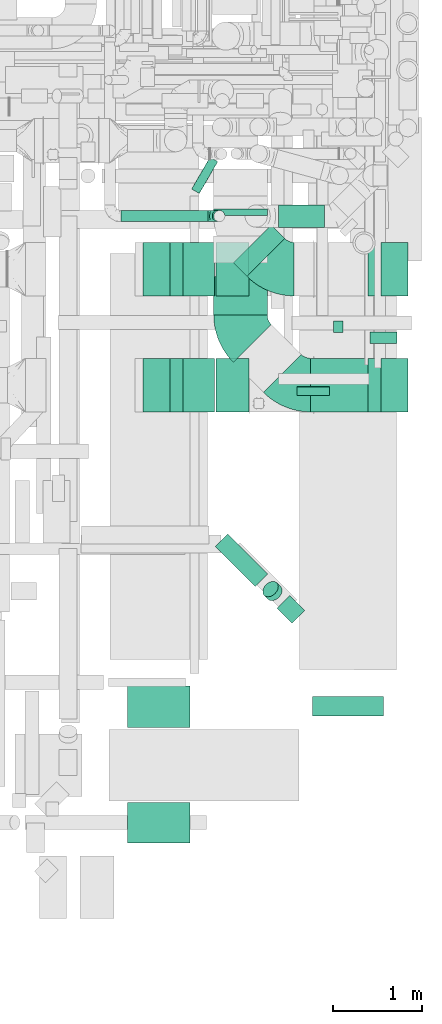
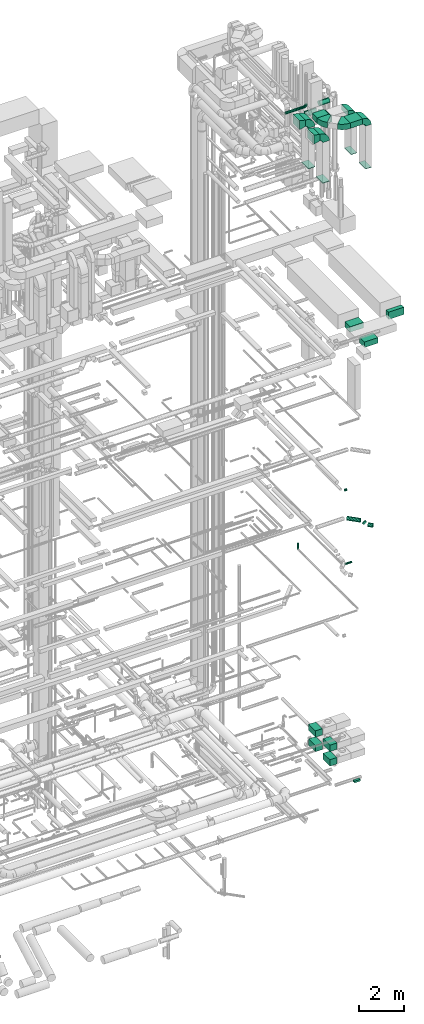
# One storey, part 297 of 337: 20 flow segments, 14 flow fittings.
"""IFC2X3 building model written with IfcOpenShell, lengths in millimetres."""

import ifcopenshell
import ifcopenshell.guid

model = None  # the IFC model being written
_history = None  # IfcOwnerHistory: only IFC2X3 demands one
_inside = {}  # id of a spatial element -> (the spatial element, [elements in it])
_under = {}  # id of a project, library or spatial element -> (it, [spatial elements below it])
_declared = {}  # id of a project -> (the project, [libraries it declares])
_typed = {}  # id of a type object -> (the type object, [elements of that type])
_made_of = {}  # id of a material, layer set ... -> (it, [elements and type objects made of it])


def new_model(schema):
    """Start an empty IFC model of exactly this schema.

    Asked for "IFC4X3", IfcOpenShell would pick the latest addendum, in which some entities
    have other attributes; the version numbers below select the first issue.
    IFC2X3 requires an IfcOwnerHistory on every rooted entity: one is made here for all.
    """
    global model, _history
    if schema == "IFC4X3":
        model = ifcopenshell.file(schema_version=(4, 3, 0, 0))
    else:
        model = ifcopenshell.file(schema=schema)
    _inside.clear()
    _under.clear()
    _declared.clear()
    _typed.clear()
    _made_of.clear()
    _history = None
    if model.schema == "IFC2X3":
        org = make("IfcOrganization", Name="unknown")
        user = make(
            "IfcPersonAndOrganization",
            ThePerson=make("IfcPerson", FamilyName="unknown"),
            TheOrganization=org,
        )
        app = make(
            "IfcApplication",
            ApplicationDeveloper=org,
            Version="unknown",
            ApplicationFullName="unknown",
            ApplicationIdentifier="unknown",
        )
        _history = make(
            "IfcOwnerHistory",
            OwningUser=user,
            OwningApplication=app,
            ChangeAction="ADDED",
            CreationDate=0,
        )
    return model


def make(cls, **values):
    """One entity of the class cls with the attributes given. An attribute that is None is left unset."""
    return model.create_entity(
        cls, **{name: value for name, value in values.items() if value is not None}
    )


def entity(cls, *values):
    """Any entity or typed value of the class cls, its attributes in the order of the schema. None: left unset."""
    e = model.create_entity(cls)
    for i, value in enumerate(values):
        if value is not None:
            e[i] = value
    return e


def rooted(cls, **values):
    """An entity with a GlobalId (a new one), such as an element, a storey or a relation."""
    return make(cls, GlobalId=ifcopenshell.guid.new(), OwnerHistory=_history, **values)


def si_unit(unit_type, name, prefix=None):
    """IfcSIUnit, for example si_unit("LENGTHUNIT", "METRE", prefix="MILLI")."""
    return make("IfcSIUnit", UnitType=unit_type, Prefix=prefix, Name=name)


def converted_unit(unit_type, name, factor, base, dimensions=None, offset=None):
    """IfcConversionBasedUnit, such as the inch: factor (a typed value) times the base unit."""
    return make(
        "IfcConversionBasedUnit"
        if offset is None
        else "IfcConversionBasedUnitWithOffset",
        ConversionOffset=offset,
        Dimensions=None
        if dimensions is None
        else entity("IfcDimensionalExponents", *dimensions),
        UnitType=unit_type,
        Name=name,
        ConversionFactor=make(
            "IfcMeasureWithUnit", ValueComponent=factor, UnitComponent=base
        ),
    )


def derived_unit(unit_type, elements):
    """IfcDerivedUnit: a product of units, each with its exponent."""
    return make(
        "IfcDerivedUnit",
        Elements=[
            make("IfcDerivedUnitElement", Unit=unit, Exponent=power)
            for unit, power in elements
        ],
        UnitType=unit_type,
    )


def assignment(units):
    """IfcUnitAssignment: the units of a project."""
    return None if units is None else make("IfcUnitAssignment", Units=units)


def point(xyz):
    """IfcCartesianPoint."""
    return None if xyz is None else make("IfcCartesianPoint", Coordinates=xyz)


def direction(xyz):
    """IfcDirection."""
    return None if xyz is None else make("IfcDirection", DirectionRatios=xyz)


def frame(location, z_axis=None, x_axis=None):
    """IfcAxis2Placement3D, a coordinate frame: its origin and axes. An axis left out is left unset."""
    return make(
        "IfcAxis2Placement3D",
        Location=point(location),
        Axis=direction(z_axis),
        RefDirection=direction(x_axis),
    )


def frame_2d(location, x_axis=None):
    """IfcAxis2Placement2D, a coordinate frame in the plane: its origin and x axis."""
    return make(
        "IfcAxis2Placement2D", Location=point(location), RefDirection=direction(x_axis)
    )


def origin():
    """The frame at (0, 0, 0) with its axes left unset."""
    return frame((0.0, 0.0, 0.0))


def origin_2d_with_axis():
    """The frame at (0, 0) in the plane with the x axis (1, 0) written out."""
    return frame_2d((0.0, 0.0), x_axis=(1.0, 0.0))


def place(relative_to, where):
    """IfcLocalPlacement: puts the frame where relative to a parent placement (None: the world)."""
    return make(
        "IfcLocalPlacement", PlacementRelTo=relative_to, RelativePlacement=where
    )


def context(
    kind, dimensions, precision=None, world=None, true_north=None, identifier=None
):
    """IfcGeometricRepresentationContext, for example the 3D "Model" context."""
    return make(
        "IfcGeometricRepresentationContext",
        ContextIdentifier=identifier,
        ContextType=kind,
        CoordinateSpaceDimension=dimensions,
        Precision=precision,
        WorldCoordinateSystem=world,
        TrueNorth=true_north,
    )


def subcontext(parent, identifier, kind, view, scale=None):
    """IfcGeometricRepresentationSubContext, for example "Body" below "Model"."""
    return make(
        "IfcGeometricRepresentationSubContext",
        ContextIdentifier=identifier,
        ContextType=kind,
        ParentContext=parent,
        TargetScale=scale,
        TargetView=view,
    )


def project(units=None, contexts=None):
    """IfcProject with its units and contexts."""
    return rooted(
        "IfcProject",
        Name="project",
        RepresentationContexts=contexts,
        UnitsInContext=assignment(units),
    )


def spatial(cls, under=None, at=None, **own):
    """A site, building, storey or space (cls), placed at a placement, below another one or the project."""
    s = rooted(cls, ObjectPlacement=at, **own)
    if under is not None:
        _under.setdefault(under.id(), (under, []))[1].append(s)
    return s


def polyline(points):
    """IfcPolyline through the points."""
    return make("IfcPolyline", Points=[point(p) for p in points])


def circle_curve(where, radius):
    """IfcCircle in the frame where."""
    return make("IfcCircle", Position=where, Radius=radius)


def parameter(value):
    """IfcParameterValue: where a trimmed curve begins or ends, as a parameter of its basis curve."""
    return model.create_entity("IfcParameterValue", value)


def trimmed(basis, trim1, trim2, sense, master):
    """IfcTrimmedCurve: the piece of a basis curve between two trims."""
    return make(
        "IfcTrimmedCurve",
        BasisCurve=basis,
        Trim1=trim1,
        Trim2=trim2,
        SenseAgreement=sense,
        MasterRepresentation=master,
    )


def segment(curve, same_sense, transition):
    """IfcCompositeCurveSegment."""
    return make(
        "IfcCompositeCurveSegment",
        Transition=transition,
        SameSense=same_sense,
        ParentCurve=curve,
    )


def composite_curve(segments, self_intersect=None):
    """IfcCompositeCurve: segments joined end to end."""
    return make("IfcCompositeCurve", Segments=segments, SelfIntersect=self_intersect)


def profile(cls, at=None, kind="AREA", **sizes):
    """A parametric profile (cls). Its sizes go by their IFC names, for example OverallWidth=200.0."""
    return make(cls, ProfileType=kind, Position=at, **sizes)


def rectangle(**sizes):
    """IfcRectangleProfileDef."""
    return profile("IfcRectangleProfileDef", **sizes)


def circle(**sizes):
    """IfcCircleProfileDef."""
    return profile("IfcCircleProfileDef", **sizes)


def outline(outer, holes=None, kind="AREA"):
    """IfcArbitraryClosedProfileDef: a profile drawn as a closed curve; with holes, ...WithVoids."""
    if holes is None:
        return make("IfcArbitraryClosedProfileDef", ProfileType=kind, OuterCurve=outer)
    return make(
        "IfcArbitraryProfileDefWithVoids",
        ProfileType=kind,
        OuterCurve=outer,
        InnerCurves=holes,
    )


def extrude(swept, where, along, depth):
    """IfcExtrudedAreaSolid: the profile swept, set in the frame where, extruded along a direction by depth."""
    return make(
        "IfcExtrudedAreaSolid",
        SweptArea=swept,
        Position=where,
        ExtrudedDirection=direction(along),
        Depth=depth,
    )


def faces_of(points, faces, orient=None, outer=None):
    """IfcFace entities. A face is a list of loops; a loop is a list of indices into points, from 0.

    orient and outer hold one flag for each loop. By default every Orientation is true, the
    first loop of a face is its IfcFaceOuterBound and the others are IfcFaceBound.
    """
    made = []
    for i, loops in enumerate(faces):
        bounds = []
        for j, loop in enumerate(loops):
            is_outer = j == 0 if outer is None else outer[i][j]
            bounds.append(
                make(
                    "IfcFaceOuterBound" if is_outer else "IfcFaceBound",
                    Bound=make("IfcPolyLoop", Polygon=[points[k] for k in loop]),
                    Orientation=True if orient is None else orient[i][j],
                )
            )
        made.append(make("IfcFace", Bounds=bounds))
    return made


def faceted_brep(points, faces, orient=None, outer=None, voids=None):
    """IfcFacetedBrep: a solid bounded by flat faces; with voids (closed shells), ...WithVoids."""
    shared = [point(p) for p in points]
    hull = make("IfcClosedShell", CfsFaces=faces_of(shared, faces, orient, outer))
    if voids is None:
        return make("IfcFacetedBrep", Outer=hull)
    return make(
        "IfcFacetedBrepWithVoids",
        Outer=hull,
        Voids=[
            make(cls, CfsFaces=faces_of(shared, fs, o, b)) for cls, fs, o, b in voids
        ],
    )


def shape(context_of_items, identifier, shape_type, items):
    """IfcShapeRepresentation: the items that make up one representation, for example the "Body"."""
    return make(
        "IfcShapeRepresentation",
        ContextOfItems=context_of_items,
        RepresentationIdentifier=identifier,
        RepresentationType=shape_type,
        Items=items,
    )


def source(mapping_origin, context_of_items, identifier, shape_type, items):
    """IfcRepresentationMap: a shape defined once, which mapped items show again and again."""
    return make(
        "IfcRepresentationMap",
        MappingOrigin=mapping_origin,
        MappedRepresentation=shape(context_of_items, identifier, shape_type, items),
    )


def transform(
    local_origin,
    x_axis=None,
    y_axis=None,
    z_axis=None,
    scale=None,
    scale2=None,
    scale3=None,
    uniform=True,
):
    """IfcCartesianTransformationOperator3D, or its non-uniform kind. x_axis, y_axis, z_axis: its Axis1, 2, 3."""
    if uniform:
        return make(
            "IfcCartesianTransformationOperator3D",
            Axis1=direction(x_axis),
            Axis2=direction(y_axis),
            LocalOrigin=point(local_origin),
            Scale=scale,
            Axis3=direction(z_axis),
        )
    return make(
        "IfcCartesianTransformationOperator3DnonUniform",
        Axis1=direction(x_axis),
        Axis2=direction(y_axis),
        LocalOrigin=point(local_origin),
        Scale=scale,
        Axis3=direction(z_axis),
        Scale2=scale2,
        Scale3=scale3,
    )


def mapped(mapping_source, mapping_target):
    """IfcMappedItem: shows the shape of a source again, moved by a transform."""
    return make(
        "IfcMappedItem", MappingSource=mapping_source, MappingTarget=mapping_target
    )


def material(Name=None, Category=None):
    """IfcMaterial."""
    return make("IfcMaterial", Name=Name, Category=Category)


def made_of(thing, what):
    """Note that an element or type object is made of a material, layer set ...; save() writes the relation."""
    if what is not None:
        _made_of.setdefault(what.id(), (what, []))[1].append(thing)
    return thing


def type_object(cls, material=None, **own):
    """A type object (cls), such as IfcWallType, which elements share."""
    return made_of(rooted(cls, **own), material)


def type_shapes(of_type, sources):
    """Give a type object the sources (RepresentationMaps) that its elements show as mapped items."""
    of_type.RepresentationMaps = sources


def element(
    cls,
    number,
    at=None,
    inside=None,
    cuts=None,
    type_object=None,
    material=None,
    context=None,
    identifier="Body",
    shape_type=None,
    held_by="IfcProductDefinitionShape",
    body=None,
    shapes=None,
    **own,
):
    """One element of the class cls, such as IfcWall. Its Tag is "e" and its number.

    at: its placement. inside: the storey or other place that contains it. cuts: it is an
    opening in that element (IfcRelVoidsElement). A single representation is given by context,
    identifier, shape_type and body (its items); several are given by shapes. held_by: the class
    of the entity that holds the representations. save() writes the other relations.
    """
    e = rooted(cls, Tag="e%d" % number, ObjectPlacement=at, **own)
    if body is not None:
        shapes = [shape(context, identifier, shape_type, body)]
    if shapes is not None:
        e.Representation = make(held_by, Representations=shapes)
    if inside is not None:
        _inside.setdefault(inside.id(), (inside, []))[1].append(e)
    if cuts is not None:
        rooted(
            "IfcRelVoidsElement", RelatingBuildingElement=cuts, RelatedOpeningElement=e
        )
    if type_object is not None:
        _typed.setdefault(type_object.id(), (type_object, []))[1].append(e)
    return made_of(e, material)


def aggregate(whole, parts):
    """IfcRelAggregates: a whole, such as a stair, and the parts it consists of."""
    return rooted("IfcRelAggregates", RelatingObject=whole, RelatedObjects=parts)


def save(model, path):
    """Write the relations noted so far, then the file.

    IfcRelAggregates (storeys below a building ...), IfcRelContainedInSpatialStructure (elements
    in a storey), IfcRelDefinesByType, IfcRelAssociatesMaterial and IfcRelDeclares: one each for
    every whole, place, type object, material and project.
    """
    for whole, parts in _under.values():
        aggregate(whole, parts)
    for where, things in _inside.values():
        rooted(
            "IfcRelContainedInSpatialStructure",
            RelatedElements=things,
            RelatingStructure=where,
        )
    for kind, things in _typed.values():
        rooted("IfcRelDefinesByType", RelatedObjects=things, RelatingType=kind)
    for what, things in _made_of.values():
        rooted("IfcRelAssociatesMaterial", RelatedObjects=things, RelatingMaterial=what)
    for by, libraries in _declared.values():
        rooted("IfcRelDeclares", RelatingContext=by, RelatedDefinitions=libraries)
    model.write(path)


model = new_model("IFC2X3")

# Units and contexts
model_context = context("Model", 3, precision=0.01, world=origin(), true_north=direction((6.12303176911189e-17, 1.0)))
body_context = subcontext(model_context, "Body", "Model", "MODEL_VIEW")
ifc_project = project(units=[si_unit("LENGTHUNIT", "METRE", prefix="MILLI"), si_unit("AREAUNIT", "SQUARE_METRE"), si_unit("VOLUMEUNIT", "CUBIC_METRE"), converted_unit("PLANEANGLEUNIT", "DEGREE", entity("IfcRatioMeasure", 0.0174532925199433), si_unit("PLANEANGLEUNIT", "RADIAN"), dimensions=[0, 0, 0, 0, 0, 0, 0]), si_unit("MASSUNIT", "GRAM", prefix="KILO"), derived_unit("MASSDENSITYUNIT", [(si_unit("MASSUNIT", "GRAM", prefix="KILO"), 1), (si_unit("LENGTHUNIT", "METRE"), -3)]), derived_unit("MOMENTOFINERTIAUNIT", [(si_unit("LENGTHUNIT", "METRE"), 4)]), si_unit("TIMEUNIT", "SECOND"), si_unit("FREQUENCYUNIT", "HERTZ"), si_unit("THERMODYNAMICTEMPERATUREUNIT", "DEGREE_CELSIUS"), derived_unit("THERMALTRANSMITTANCEUNIT", [(si_unit("MASSUNIT", "GRAM", prefix="KILO"), 1), (si_unit("THERMODYNAMICTEMPERATUREUNIT", "KELVIN"), -1), (si_unit("TIMEUNIT", "SECOND"), -3)]), derived_unit("VOLUMETRICFLOWRATEUNIT", [(si_unit("LENGTHUNIT", "METRE"), 3), (si_unit("TIMEUNIT", "SECOND"), -1)]), derived_unit("MASSFLOWRATEUNIT", [(si_unit("MASSUNIT", "GRAM", prefix="KILO"), 1), (si_unit("TIMEUNIT", "SECOND"), -1)]), derived_unit("ROTATIONALFREQUENCYUNIT", [(si_unit("TIMEUNIT", "SECOND"), -1)]), si_unit("ELECTRICCURRENTUNIT", "AMPERE"), si_unit("ELECTRICVOLTAGEUNIT", "VOLT"), si_unit("POWERUNIT", "WATT"), si_unit("FORCEUNIT", "NEWTON", prefix="KILO"), si_unit("ILLUMINANCEUNIT", "LUX"), si_unit("LUMINOUSFLUXUNIT", "LUMEN"), si_unit("LUMINOUSINTENSITYUNIT", "CANDELA"), derived_unit("USERDEFINED", [(si_unit("MASSUNIT", "GRAM", prefix="KILO"), -1), (si_unit("LENGTHUNIT", "METRE"), -2), (si_unit("TIMEUNIT", "SECOND"), 3), (si_unit("LUMINOUSFLUXUNIT", "LUMEN"), 1)]), derived_unit("LINEARVELOCITYUNIT", [(si_unit("LENGTHUNIT", "METRE"), 1), (si_unit("TIMEUNIT", "SECOND"), -1)]), si_unit("PRESSUREUNIT", "PASCAL"), derived_unit("USERDEFINED", [(si_unit("LENGTHUNIT", "METRE"), -2), (si_unit("MASSUNIT", "GRAM", prefix="KILO"), 1), (si_unit("TIMEUNIT", "SECOND"), -2)]), derived_unit("LINEARFORCEUNIT", [(si_unit("MASSUNIT", "GRAM", prefix="KILO"), 1), (si_unit("LENGTHUNIT", "METRE"), 1), (si_unit("TIMEUNIT", "SECOND"), -2), (si_unit("LENGTHUNIT", "METRE"), -1)]), derived_unit("PLANARFORCEUNIT", [(si_unit("MASSUNIT", "GRAM", prefix="KILO"), 1), (si_unit("LENGTHUNIT", "METRE"), 1), (si_unit("TIMEUNIT", "SECOND"), -2), (si_unit("LENGTHUNIT", "METRE"), -2)])], contexts=[model_context])

# Site, building, storey
site_placement = place(None, origin())
site = spatial("IfcSite", under=ifc_project, at=site_placement, CompositionType="ELEMENT")
building_placement = place(site_placement, origin())
building = spatial("IfcBuilding", under=site, at=building_placement, CompositionType="ELEMENT")
storey_placement = place(building_placement, origin())
storey = spatial("IfcBuildingStorey", under=building, at=storey_placement, CompositionType="ELEMENT", Elevation=0.0)

# Flow segments
duct_segment_type_1 = type_object("IfcDuctSegmentType", PredefinedType="NOTDEFINED")
flow_segment_1_placement = place(storey_placement, frame((72674.13, 6921.16, -1100.0)))
element("IfcFlowSegment", 1, at=flow_segment_1_placement, inside=storey, type_object=duct_segment_type_1, context=body_context, shape_type="SweptSolid", body=[
    extrude(rectangle(XDim=129.999999999996, YDim=300.000000000001, at=origin_2d_with_axis()), frame((150.0, 65.0, 0.0), z_axis=(0.0, 0.0, 1.0), x_axis=(0.0, -1.0, 0.0)), (0.0, 0.0, 1.0), 100.0),
])
flow_segment_2_placement = place(storey_placement, frame((70946.93, 6153.72, 1695.71)))
element("IfcFlowSegment", 2, at=flow_segment_2_placement, inside=storey, type_object=duct_segment_type_1, context=body_context, shape_type="SweptSolid", body=[
    extrude(rectangle(XDim=367.301557999939, YDim=600.0, at=origin_2d_with_axis()), frame((183.65, 300.0, 0.0), z_axis=(0.0, 0.0, 1.0), x_axis=(-1.0, 0.0, 0.0)), (0.0, 0.0, 1.0), 350.0),
])
flow_segment_3_placement = place(storey_placement, frame((70946.93, 6153.72, 895.71)))
element("IfcFlowSegment", 3, at=flow_segment_3_placement, inside=storey, type_object=duct_segment_type_1, context=body_context, shape_type="SweptSolid", body=[
    extrude(rectangle(XDim=367.301557999939, YDim=600.0, at=origin_2d_with_axis()), frame((183.65, 300.0, 0.0)), (0.0, 0.0, 1.0), 350.0),
])
flow_segment_4_placement = place(storey_placement, frame((72006.16, 6153.72, 35500.0)))
element("IfcFlowSegment", 4, at=flow_segment_4_placement, inside=storey, type_object=duct_segment_type_1, context=body_context, shape_type="SweptSolid", body=[
    extrude(rectangle(XDim=640.769865278916, YDim=600.0, at=origin_2d_with_axis()), frame((320.38, 300.0, 0.0), z_axis=(0.0, 0.0, 1.0), x_axis=(-1.0, 0.0, 0.0)), (0.0, 0.0, 1.0), 300.000000000001),
])
flow_segment_5_placement = place(storey_placement, frame((70919.75, 7240.14, 35500.0)))
element("IfcFlowSegment", 5, at=flow_segment_5_placement, inside=storey, type_object=duct_segment_type_1, context=body_context, shape_type="SweptSolid", body=[
    extrude(rectangle(XDim=433.440596927154, YDim=600.000000000002, at=origin_2d_with_axis()), frame((300.0, 216.72, 0.0), z_axis=(0.0, 0.0, 1.0), x_axis=(0.0, 1.0, 0.0)), (0.0, 0.0, 1.0), 300.000000000001),
])
flow_segment_6_placement = place(storey_placement, frame((71139.42, 7673.35, 35150.0)))
element("IfcFlowSegment", 6, at=flow_segment_6_placement, inside=storey, type_object=duct_segment_type_1, context=body_context, shape_type="SweptSolid", body=[
    extrude(rectangle(XDim=213.712570360395, YDim=600.000000000003, at=origin_2d_with_axis()), frame((287.69, 287.69, 0.0), z_axis=(0.0, 0.0, 1.0), x_axis=(0.70710678118654, -0.707106781186555, 0.0)), (0.0, 0.0, 1.0), 300.000000000001),
])
flow_segment_7_placement = place(storey_placement, frame((70919.75, 8354.8, 35150.0)))
element("IfcFlowSegment", 7, at=flow_segment_7_placement, inside=storey, type_object=duct_segment_type_1, context=body_context, shape_type="SweptSolid", body=[
    extrude(rectangle(XDim=70.1850022281798, YDim=600.000000000002, at=origin_2d_with_axis()), frame((300.0, 35.09, 0.0), z_axis=(0.0, 0.0, 1.0), x_axis=(0.0, 1.0, 0.0)), (0.0, 0.0, 1.0), 300.000000000001),
])
for number, where in (
    (8, (70946.93, 7453.68, 1695.71)),
    (9, (70946.93, 7453.68, 895.71)),
):
    element("IfcFlowSegment", number, at=place(storey_placement, frame(where)), inside=storey, type_object=duct_segment_type_1, context=body_context, shape_type="SweptSolid", body=[
        extrude(rectangle(XDim=367.301557999931, YDim=600.0, at=origin_2d_with_axis()), frame((183.65, 300.0, 0.0), z_axis=(0.0, 0.0, 1.0), x_axis=(-1.0, 0.0, 0.0)), (0.0, 0.0, 1.0), 350.0),
    ])
flow_segment_8_placement = place(storey_placement, frame((72024.08, 2743.43, 27085.0)))
element("IfcFlowSegment", 10, at=flow_segment_8_placement, inside=storey, type_object=duct_segment_type_1, context=body_context, shape_type="SweptSolid", body=[
    extrude(rectangle(XDim=219.950212784692, YDim=799.999999999996, at=origin_2d_with_axis()), frame((400.01, 110.02, 0.0), z_axis=(0.0, 0.0, 1.0), x_axis=(-0.000101789703805848, 0.999999994819428, 0.0)), (0.0, 0.0, 1.0), 400.000000000004),
])
flow_segment_9_placement = place(storey_placement, frame((69953.15, 2613.41, 27190.0)))
element("IfcFlowSegment", 11, at=flow_segment_9_placement, inside=storey, type_object=duct_segment_type_1, context=body_context, shape_type="SweptSolid", body=[
    extrude(rectangle(XDim=465.956559520461, YDim=699.999999999997, at=origin_2d_with_axis()), frame((350.0, 232.98, 0.0), z_axis=(0.0, 0.0, 1.0), x_axis=(0.0, -1.0, 0.0)), (0.0, 0.0, 1.0), 300.000000000001),
])
flow_segment_10_placement = place(storey_placement, frame((69953.15, 1323.12, 27135.0)))
element("IfcFlowSegment", 12, at=flow_segment_10_placement, inside=storey, type_object=duct_segment_type_1, context=body_context, shape_type="SweptSolid", body=[
    extrude(rectangle(XDim=450.290700683882, YDim=699.999999999997, at=origin_2d_with_axis()), frame((350.0, 225.15, 0.0), z_axis=(0.0, 0.0, 1.0), x_axis=(0.0, -1.0, 0.0)), (0.0, 0.0, 1.0), 300.000000000001),
])
duct_segment_type_2 = type_object("IfcDuctSegmentType", PredefinedType="NOTDEFINED")
flow_segment_11_placement = place(storey_placement, frame((70933.32, 4193.93, 15248.19)))
element("IfcFlowSegment", 13, at=flow_segment_11_placement, inside=storey, type_object=duct_segment_type_2, context=body_context, shape_type="SweptSolid", body=[
    extrude(circle(Radius=100.0, at=origin_2d_with_axis()), frame((72.31, 522.07, 101.6), z_axis=(0.707106780712137, -0.707106780712155, 3.66307440572479e-05), x_axis=(-0.707106781186557, -0.707106781186539, 0.0)), (0.0, 0.0, 1.0), 636.055719788718),
])
flow_segment_12_placement = place(storey_placement, frame((71468.71, 4036.8, 15158.27)))
element("IfcFlowSegment", 14, at=flow_segment_12_placement, inside=storey, type_object=duct_segment_type_2, context=body_context, shape_type="SweptSolid", body=[
    extrude(circle(Radius=100.0, at=origin_2d_with_axis()), frame((130.7, 87.83, 72.31), z_axis=(-0.500000000000039, 0.499999999999994, 0.707106781186524), x_axis=(-0.707106781186509, -0.707106781186586, 0.0)), (0.0, 0.0, 1.0), 85.7421897452959),
])
flow_segment_13_placement = place(storey_placement, frame((71627.11, 3784.63, 15070.4)))
element("IfcFlowSegment", 15, at=flow_segment_13_placement, inside=storey, type_object=duct_segment_type_2, context=body_context, shape_type="SweptSolid", body=[
    extrude(circle(Radius=100.0, at=origin_2d_with_axis()), frame((240.0, 72.31, 101.6), z_axis=(-0.707106781186566, 0.707106781186529, 0.0), x_axis=(-0.707106781186529, -0.707106781186566, 0.0)), (0.0, 0.0, 1.0), 237.157287525395),
])
flow_segment_14_placement = place(storey_placement, frame((70670.42, 8599.49, 11348.4)))
element("IfcFlowSegment", 16, at=flow_segment_14_placement, inside=storey, type_object=duct_segment_type_2, context=body_context, shape_type="SweptSolid", body=[
    extrude(circle(Radius=50.0, at=origin_2d_with_axis()), frame((44.9, 26.6, 51.6), z_axis=(0.500000000000028, 0.866025403784423, 0.0), x_axis=(0.866025403784423, -0.500000000000028, 0.0)), (0.0, 0.0, 1.0), 413.20508075689),
])
flow_segment_15_placement = place(storey_placement, frame((72260.41, 7043.73, 14935.9)))
element("IfcFlowSegment", 17, at=flow_segment_15_placement, inside=storey, type_object=duct_segment_type_2, context=body_context, shape_type="SweptSolid", body=[
    extrude(circle(Radius=62.5, at=origin_2d_with_axis()), frame((0.0, 64.1, 64.1), z_axis=(1.0, 0.0, 0.0), x_axis=(0.0, -1.0, 0.0)), (0.0, 0.0, 1.0), 106.163350815386),
])
flow_segment_16_placement = place(storey_placement, frame((71854.89, 6335.2, 11468.4)))
element("IfcFlowSegment", 18, at=flow_segment_16_placement, inside=storey, type_object=duct_segment_type_2, context=body_context, shape_type="SweptSolid", body=[
    extrude(circle(Radius=50.0, at=origin_2d_with_axis()), frame((0.0, 51.6, 51.6), z_axis=(1.0, 0.0, 0.0), x_axis=(0.0, -1.0, 0.0)), (0.0, 0.0, 1.0), 359.999999999979),
])
flow_segment_17_placement = place(storey_placement, frame((69882.45, 8284.03, 35685.9)))
element("IfcFlowSegment", 19, at=flow_segment_17_placement, inside=storey, type_object=duct_segment_type_2, context=body_context, shape_type="SweptSolid", body=[
    extrude(circle(Radius=62.5, at=origin_2d_with_axis()), frame((0.0, 64.1, 64.1), z_axis=(1.0, 0.0, 0.0), x_axis=(0.0, -1.0, 0.0)), (0.0, 0.0, 1.0), 975.000000000125),
])
flow_segment_18_placement = place(storey_placement, frame((71645.58, 8221.53, 35548.4)))
element("IfcFlowSegment", 20, at=flow_segment_18_placement, inside=storey, type_object=duct_segment_type_2, context=body_context, shape_type="SweptSolid", body=[
    extrude(circle(Radius=125.0, at=origin_2d_with_axis()), frame((0.0, 126.6, 126.6), z_axis=(1.0, 0.0, 0.0), x_axis=(0.0, -1.0, 0.0)), (0.0, 0.0, 1.0), 516.731637259526),
])

# Flow fittings
ifc_material = material()
duct_fitting_type_1 = type_object("IfcDuctFittingType", PredefinedType="NOTDEFINED", material=ifc_material)
shared_shape_1 = source(origin(), body_context, "Body", "SweptSolid", [
    extrude(rectangle(XDim=24.9999999999999, YDim=600.0, at=origin_2d_with_axis()), frame((12.5, 0.0, -150.0)), (0.0, 0.0, 1.0), 300.0),
])
type_shapes(duct_fitting_type_1, [shared_shape_1])
for number, where, z_axis, x_axis in (
    (21, (72946.93, 6453.72, 33010.0), (-1.0, 0.0, 0.0), (0.0, 0.0, -1.0)),
    (22, (72946.93, 7753.68, 33010.0), (-1.0, 0.0, 0.0), (0.0, 0.0, -1.0)),
):
    element("IfcFlowFitting", number, at=place(storey_placement, frame(where, z_axis=z_axis, x_axis=x_axis)), inside=storey, type_object=duct_fitting_type_1, material=ifc_material, context=body_context, shape_type="MappedRepresentation", body=[
        mapped(shared_shape_1, transform((0.0, 0.0, 0.0), scale=1.0)),
    ])
duct_fitting_type_2 = type_object("IfcDuctFittingType", PredefinedType="NOTDEFINED", material=ifc_material)
shared_shape_2 = source(origin(), body_context, "Body", "SweptSolid", [
    extrude(outline(polyline([(-206.16, -206.16), (103.08, -206.16), (187.97, 133.39), (-84.89, 278.92), (-206.16, -206.16)])), frame((150.0, -300.0, 0.0), z_axis=(0.0, 1.0, 0.0), x_axis=(0.97014250014531, 0.0, -0.242535625036422)), (0.0, 0.0, 1.0), 600.0),
])
type_shapes(duct_fitting_type_2, [shared_shape_2])
for number, where in (
    (23, (70126.93, 6453.72, 35550.0)),
    (24, (70126.93, 7753.72, 35550.0)),
):
    element("IfcFlowFitting", number, at=place(storey_placement, frame(where)), inside=storey, type_object=duct_fitting_type_2, material=ifc_material, context=body_context, shape_type="MappedRepresentation", body=[
        mapped(shared_shape_2, transform((0.0, 0.0, 0.0), scale=1.0)),
    ])
duct_fitting_type_3 = type_object("IfcDuctFittingType", PredefinedType="NOTDEFINED", material=ifc_material)
shared_shape_3 = source(origin(), body_context, "Body", "SweptSolid", [
    extrude(rectangle(XDim=24.9999999999999, YDim=600.0, at=origin_2d_with_axis()), frame((12.5, 0.0, -175.0)), (0.0, 0.0, 1.0), 350.0),
])
type_shapes(duct_fitting_type_3, [shared_shape_3])
for number, where, z_axis, x_axis in (
    (25, (70751.93, 6453.72, 33010.0), (-1.0, 0.0, 0.0), (0.0, 0.0, -1.0)),
    (26, (70751.93, 7753.68, 33010.0), (-1.0, 0.0, 0.0), (0.0, 0.0, -1.0)),
):
    element("IfcFlowFitting", number, at=place(storey_placement, frame(where, z_axis=z_axis, x_axis=x_axis)), inside=storey, type_object=duct_fitting_type_3, material=ifc_material, context=body_context, shape_type="MappedRepresentation", body=[
        mapped(shared_shape_3, transform((0.0, 0.0, 0.0), scale=1.0)),
    ])
duct_fitting_type_4 = type_object("IfcDuctFittingType", PredefinedType="NOTDEFINED", material=ifc_material)
shared_shape_4 = source(origin(), body_context, "Body", "Brep", [
    faceted_brep([(-125.0, 0.0, -62.5), (-125.0, -16.18, -60.37), (-125.0, -31.25, -54.13), (-125.0, -44.19, -44.19), (-125.0, -54.13, -31.25), (-125.0, -60.37, -16.18), (-125.0, -62.5, 0.0), (-125.0, -60.37, 16.18), (-125.0, -54.13, 31.25), (-125.0, -44.19, 44.19), (-125.0, -31.25, 54.13), (-125.0, -16.18, 60.37), (-125.0, 0.0, 62.5), (-125.0, 16.18, 60.37), (-125.0, 31.25, 54.13), (-125.0, 44.19, 44.19), (-125.0, 54.13, 31.25), (-125.0, 60.37, 16.18), (-125.0, 62.5, 0.0), (-125.0, 60.37, -16.18), (-125.0, 54.13, -31.25), (-125.0, 44.19, -44.19), (-125.0, 31.25, -54.13), (-125.0, 16.18, -60.37), (-95.84, 16.18, 60.37), (-99.88, 31.25, 54.13), (-91.51, 0.0, 62.5), (-103.35, 44.19, 44.19), (-107.68, 60.37, 16.18), (-108.25, 62.5, 0.0), (-106.01, 54.13, 31.25), (-106.01, 54.13, -31.25), (-103.35, 44.19, -44.19), (-107.68, 60.37, -16.18), (-95.84, 16.18, -60.37), (-91.51, 0.0, -62.5), (-99.88, 31.25, -54.13), (-87.17, -16.18, -60.37), (-83.13, -31.25, -54.13), (-79.66, -44.19, -44.19), (-77.0, -54.13, -31.25), (-75.33, -60.37, -16.18), (-74.76, -62.5, 0.0), (-75.33, -60.37, 16.18), (-77.0, -54.13, 31.25), (-79.66, -44.19, 44.19), (-83.13, -31.25, 54.13), (-87.17, -16.18, 60.37), (-45.34, 45.34, 60.37), (-56.37, 56.37, 54.13), (-33.49, 33.49, 62.5), (-65.85, 65.85, 44.19), (-73.12, 73.12, 31.25), (-77.69, 77.69, 16.18), (-79.25, 79.25, 0.0), (-77.69, 77.69, -16.18), (-73.12, 73.12, -31.25), (-65.85, 65.85, -44.19), (-45.34, 45.34, -60.37), (-33.49, 33.49, -62.5), (-56.37, 56.37, -54.13), (-21.65, 21.65, -60.37), (-10.62, 10.62, -54.13), (-1.14, 1.14, -44.19), (6.13, -6.13, -31.25), (10.7, -10.7, -16.18), (12.26, -12.26, 0.0), (10.7, -10.7, 16.18), (6.13, -6.13, 31.25), (-1.14, 1.14, 44.19), (-10.62, 10.62, 54.13), (-21.65, 21.65, 60.37), (-16.18, 95.84, 60.37), (-31.25, 99.88, 54.13), (0.0, 91.51, 62.5), (-44.19, 103.35, 44.19), (-54.13, 106.01, 31.25), (-60.37, 107.68, 16.18), (-62.5, 108.25, 0.0), (-60.37, 107.68, -16.18), (-54.13, 106.01, -31.25), (-44.19, 103.35, -44.19), (-16.18, 95.84, -60.37), (0.0, 91.51, -62.5), (-31.25, 99.88, -54.13), (16.18, 87.17, -60.37), (31.25, 83.13, -54.13), (44.19, 79.66, -44.19), (54.13, 77.0, -31.25), (60.37, 75.33, -16.18), (62.5, 74.76, 0.0), (60.37, 75.33, 16.18), (54.13, 77.0, 31.25), (44.19, 79.66, 44.19), (31.25, 83.13, 54.13), (16.18, 87.17, 60.37), (-16.18, 125.0, -60.37), (-31.25, 125.0, -54.13), (-44.19, 125.0, -44.19), (-54.13, 125.0, -31.25), (-60.37, 125.0, -16.18), (-62.5, 125.0, 0.0), (-60.37, 125.0, 16.18), (-54.13, 125.0, 31.25), (-44.19, 125.0, 44.19), (-31.25, 125.0, 54.13), (-16.18, 125.0, 60.37), (0.0, 125.0, 62.5), (16.18, 125.0, 60.37), (31.25, 125.0, 54.13), (44.19, 125.0, 44.19), (54.13, 125.0, 31.25), (60.37, 125.0, 16.18), (62.5, 125.0, 0.0), (60.37, 125.0, -16.18), (54.13, 125.0, -31.25), (44.19, 125.0, -44.19), (31.25, 125.0, -54.13), (16.18, 125.0, -60.37), (0.0, 125.0, -62.5)], [[[0, 1, 2, 3, 4, 5, 6, 7, 8, 9, 10, 11, 12, 13, 14, 15, 16, 17, 18, 19, 20, 21, 22, 23]], [[24, 25, 14, 13]], [[26, 24, 13, 12]], [[14, 25, 27, 15]], [[28, 29, 18, 17]], [[30, 28, 17, 16]], [[15, 27, 30, 16]], [[20, 31, 32, 21]], [[33, 31, 20, 19]], [[18, 29, 33, 19]], [[34, 35, 0, 23]], [[36, 34, 23, 22]], [[21, 32, 36, 22]], [[1, 0, 35, 37]], [[2, 1, 37, 38]], [[38, 39, 3, 2]], [[5, 4, 40, 41]], [[6, 5, 41, 42]], [[39, 40, 4, 3]], [[6, 42, 43, 7]], [[7, 43, 44, 8]], [[45, 9, 8, 44]], [[9, 45, 46, 10]], [[10, 46, 47, 11]], [[26, 12, 11, 47]], [[48, 49, 25, 24]], [[50, 48, 24, 26]], [[27, 25, 49, 51]], [[52, 53, 28, 30]], [[51, 52, 30, 27]], [[29, 28, 53, 54]], [[55, 56, 31, 33]], [[54, 55, 33, 29]], [[57, 32, 31, 56]], [[58, 59, 35, 34]], [[60, 58, 34, 36]], [[57, 60, 36, 32]], [[37, 35, 59, 61]], [[38, 37, 61, 62]], [[39, 38, 62, 63]], [[41, 40, 64, 65]], [[42, 41, 65, 66]], [[63, 64, 40, 39]], [[43, 42, 66, 67]], [[44, 43, 67, 68]], [[68, 69, 45, 44]], [[46, 45, 69, 70]], [[47, 46, 70, 71]], [[26, 47, 71, 50]], [[72, 73, 49, 48]], [[74, 72, 48, 50]], [[51, 49, 73, 75]], [[76, 77, 53, 52]], [[75, 76, 52, 51]], [[54, 53, 77, 78]], [[79, 80, 56, 55]], [[78, 79, 55, 54]], [[81, 57, 56, 80]], [[82, 83, 59, 58]], [[84, 82, 58, 60]], [[81, 84, 60, 57]], [[61, 59, 83, 85]], [[62, 61, 85, 86]], [[63, 62, 86, 87]], [[65, 64, 88, 89]], [[66, 65, 89, 90]], [[87, 88, 64, 63]], [[67, 66, 90, 91]], [[68, 67, 91, 92]], [[92, 93, 69, 68]], [[70, 69, 93, 94]], [[71, 70, 94, 95]], [[50, 71, 95, 74]], [[96, 97, 98, 99, 100, 101, 102, 103, 104, 105, 106, 107, 108, 109, 110, 111, 112, 113, 114, 115, 116, 117, 118, 119]], [[72, 74, 107, 106]], [[73, 72, 106, 105]], [[75, 73, 105, 104]], [[77, 76, 103, 102]], [[78, 77, 102, 101]], [[75, 104, 103, 76]], [[78, 101, 100, 79]], [[79, 100, 99, 80]], [[80, 99, 98, 81]], [[96, 119, 83, 82]], [[97, 96, 82, 84]], [[84, 81, 98, 97]], [[83, 119, 118, 85]], [[85, 118, 117, 86]], [[116, 87, 86, 117]], [[88, 115, 114, 89]], [[89, 114, 113, 90]], [[115, 88, 87, 116]], [[91, 90, 113, 112]], [[92, 91, 112, 111]], [[111, 110, 93, 92]], [[95, 94, 109, 108]], [[74, 95, 108, 107]], [[110, 109, 94, 93]]]),
])
type_shapes(duct_fitting_type_4, [shared_shape_4])
flow_fitting_placement = place(storey_placement, frame((70982.45, 8348.12, 35750.0), z_axis=(0.0, -1.0, 0.0), x_axis=(1.0, 0.0, 0.0)))
element("IfcFlowFitting", 27, at=flow_fitting_placement, inside=storey, type_object=duct_fitting_type_4, material=ifc_material, context=body_context, shape_type="MappedRepresentation", body=[
    mapped(shared_shape_4, transform((0.0, 0.0, 0.0), scale=1.0)),
])
duct_fitting_type_5 = type_object("IfcDuctFittingType", PredefinedType="NOTDEFINED", material=ifc_material)
shared_shape_5 = source(origin(), body_context, "Body", "SweptSolid", [
    extrude(outline(composite_curve([segment(polyline([(-365.9, -159.1), (234.1, -159.1)]), True, "CONTINUOUS"), segment(trimmed(circle_curve(frame_2d((384.1, -159.1), x_axis=(-0.707106781186553, 0.707106781186546)), 150.0), [parameter(0.0)], [parameter(45.0)], True, "PARAMETER"), False, "CONTINUOUS"), segment(polyline([(278.03, -53.03), (-146.23, 371.23)]), True, "CONTINUOUS"), segment(trimmed(circle_curve(frame_2d((384.1, -159.1), x_axis=(-0.707106781186553, 0.707106781186546)), 750.0), [parameter(0.0)], [parameter(45.0)], True, "PARAMETER"), True, "CONTINUOUS")], self_intersect=False)), frame((-27.3, 65.9, -150.0), z_axis=(0.0, 0.0, 1.0), x_axis=(-0.707106781186547, 0.707106781186548, 0.0)), (0.0, 0.0, 1.0), 300.0),
])
type_shapes(duct_fitting_type_5, [shared_shape_5])
for number, where, z_axis, x_axis in (
    (28, (71819.77, 6453.72, 35650.0), (0.0, 0.0, 1.0), (0.707106781186557, -0.707106781186538, 0.0)),
    (29, (71219.75, 7053.74, 35650.0), (0.0, 0.0, 1.0), (0.0, -1.0, 0.0)),
    (30, (71634.47, 7753.68, 35300.0), (0.0, 0.0, 1.0), (0.70710678118654, -0.707106781186555, 0.0)),
):
    element("IfcFlowFitting", number, at=place(storey_placement, frame(where, z_axis=z_axis, x_axis=x_axis)), inside=storey, type_object=duct_fitting_type_5, material=ifc_material, context=body_context, shape_type="MappedRepresentation", body=[
        mapped(shared_shape_5, transform((0.0, 0.0, 0.0), scale=1.0)),
    ])
duct_fitting_type_6 = type_object("IfcDuctFittingType", PredefinedType="NOTDEFINED", material=ifc_material)
shared_shape_6 = source(origin(), body_context, "Body", "SweptSolid", [
    extrude(outline(composite_curve([segment(polyline([(-337.5, -162.5), (12.5, -162.5)]), True, "CONTINUOUS"), segment(trimmed(circle_curve(frame_2d((162.5, -162.5), x_axis=(0.0, 1.0)), 150.0), [parameter(0.0)], [parameter(90.0000000000001)], True, "PARAMETER"), False, "CONTINUOUS"), segment(polyline([(162.5, -12.5), (162.5, 337.5)]), True, "CONTINUOUS"), segment(trimmed(circle_curve(frame_2d((162.5, -162.5), x_axis=(0.0, 1.0)), 500.0), [parameter(0.0)], [parameter(90.0000000000001)], True, "PARAMETER"), True, "CONTINUOUS")], self_intersect=False)), frame((-162.5, 162.5, -300.0), z_axis=(0.0, 0.0, 1.0), x_axis=(-1.0, 0.0, 0.0)), (0.0, 0.0, 1.0), 600.0),
])
type_shapes(duct_fitting_type_6, [shared_shape_6])
for number, where, z_axis, x_axis in (
    (31, (70751.93, 6453.72, 35550.0), (0.0, 1.0, 0.0), (1.0, 0.0, 0.0)),
    (32, (70751.93, 7753.72, 35550.0), (0.0, 1.0, 0.0), (1.0, 0.0, 0.0)),
):
    element("IfcFlowFitting", number, at=place(storey_placement, frame(where, z_axis=z_axis, x_axis=x_axis)), inside=storey, type_object=duct_fitting_type_6, material=ifc_material, context=body_context, shape_type="MappedRepresentation", body=[
        mapped(shared_shape_6, transform((0.0, 0.0, 0.0), scale=1.0)),
    ])
duct_fitting_type_7 = type_object("IfcDuctFittingType", PredefinedType="NOTDEFINED", material=ifc_material)
shared_shape_7 = source(origin(), body_context, "Body", "SweptSolid", [
    extrude(outline(composite_curve([segment(polyline([(-300.0, -150.0), (0.0, -150.0)]), True, "CONTINUOUS"), segment(trimmed(circle_curve(frame_2d((150.0, -150.0), x_axis=(0.0, 1.0)), 150.0), [parameter(0.0)], [parameter(90.0)], True, "PARAMETER"), False, "CONTINUOUS"), segment(polyline([(150.0, 0.0), (150.0, 300.0)]), True, "CONTINUOUS"), segment(trimmed(circle_curve(frame_2d((150.0, -150.0), x_axis=(0.0, 1.0)), 450.0), [parameter(0.0)], [parameter(90.0000000000001)], True, "PARAMETER"), True, "CONTINUOUS")], self_intersect=False)), frame((-150.0, 150.0, -300.0), z_axis=(0.0, 0.0, 1.0), x_axis=(-1.0, 0.0, 0.0)), (0.0, 0.0, 1.0), 600.0),
])
type_shapes(duct_fitting_type_7, [shared_shape_7])
for number, where, z_axis, x_axis in (
    (33, (72946.93, 6453.72, 35650.0), (0.0, -1.0, 0.0), (0.0, 0.0, 1.0)),
    (34, (72946.93, 7753.68, 35300.0), (0.0, -1.0, 0.0), (0.0, 0.0, 1.0)),
):
    element("IfcFlowFitting", number, at=place(storey_placement, frame(where, z_axis=z_axis, x_axis=x_axis)), inside=storey, type_object=duct_fitting_type_7, material=ifc_material, context=body_context, shape_type="MappedRepresentation", body=[
        mapped(shared_shape_7, transform((0.0, 0.0, 0.0), scale=1.0)),
    ])

save(model, "model.ifc")
